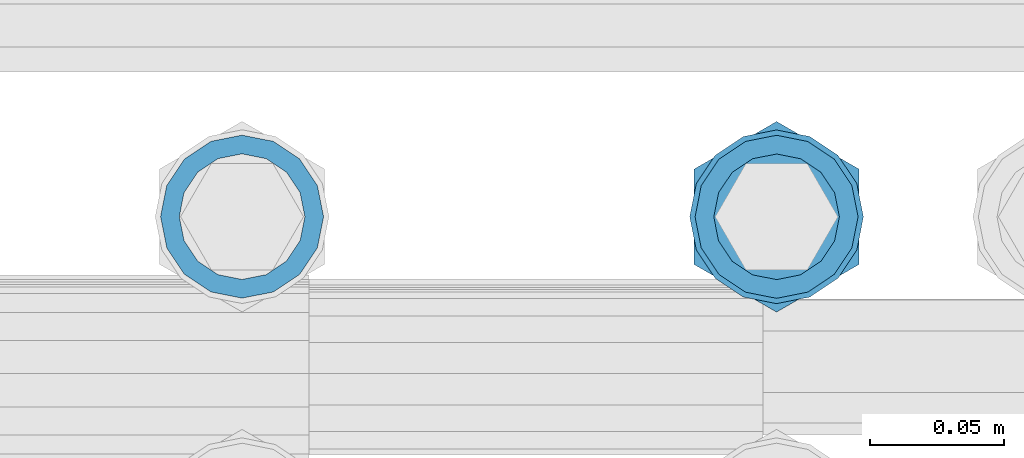
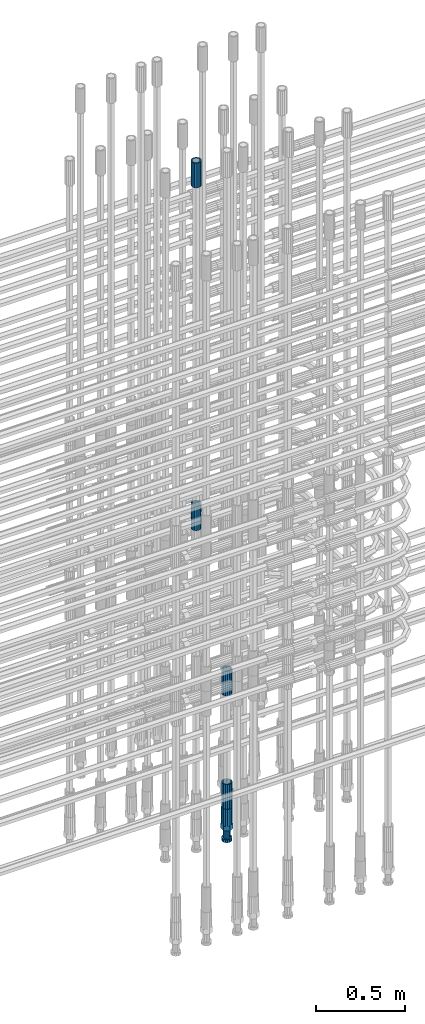
# One storey, part 18 of 119: 5 beams.
"""IFC2X3 building model written with IfcOpenShell, lengths in millimetres."""

from ifc_helpers import new_model, si_unit, frame, origin_with_axes, place, context, subcontext, project, spatial, faceted_brep, material, type_object, element, save


model = new_model("IFC2X3")

# Units and contexts
model_context = context("Model", 3, precision=1e-05, world=origin_with_axes())
body_context = subcontext(model_context, "Body", "Model", "MODEL_VIEW")
ifc_project = project(units=[si_unit("LENGTHUNIT", "METRE", prefix="MILLI"), si_unit("AREAUNIT", "SQUARE_METRE"), si_unit("VOLUMEUNIT", "CUBIC_METRE"), si_unit("MASSUNIT", "GRAM", prefix="KILO"), si_unit("TIMEUNIT", "SECOND"), si_unit("PLANEANGLEUNIT", "RADIAN"), si_unit("SOLIDANGLEUNIT", "STERADIAN"), si_unit("THERMODYNAMICTEMPERATUREUNIT", "DEGREE_CELSIUS"), si_unit("LUMINOUSINTENSITYUNIT", "LUMEN")], contexts=[model_context])

# Site, building, storey
site_placement = place(None, origin_with_axes())
site = spatial("IfcSite", under=ifc_project, at=site_placement, CompositionType="ELEMENT")
building_placement = place(site_placement, origin_with_axes())
building = spatial("IfcBuilding", under=site, at=building_placement, Name="Undefined", CompositionType="ELEMENT")
storey_placement = place(building_placement, origin_with_axes())
storey = spatial("IfcBuildingStorey", under=building, at=storey_placement, Name="Undefined", CompositionType="ELEMENT", Elevation=0.0)

# Beams
ifc_material = material(Name="STEEL/S275")
beam_type_1 = type_object("IfcBeamType", PredefinedType="NOTDEFINED")
beam_1_placement = place(storey_placement, frame((2035325.00639737, 6205269.05477611, 23229.985729163), z_axis=(1.0, 0.0, 0.0), x_axis=(0.0, 0.0, 1.0)))
element("IfcBeam", 1, at=beam_1_placement, inside=storey, type_object=beam_type_1, material=ifc_material, Name="AG40N", context=body_context, shape_type="Brep", body=[
    faceted_brep([(1.62981450557709e-09, -23.4999999990687, 0.0), (7.45058059692383e-09, -21.7111690142192, 8.99306066057534), (170.000002125278, -21.711168999318, 8.99306066022245), (170.000002127141, -23.4999999844003, -3.66071617463604e-10), (4.65661287307739e-09, -16.6170093587134, 16.6170093578889), (170.000002122484, -16.6170093440451, 16.6170093575288), (1.86264514923096e-09, -8.99306066217832, 21.7111690140277), (170.000002118759, -8.99306064750999, 21.7111690136603), (2.3283064365387e-10, 9.31322574615479e-10, 23.5), (170.000002114102, 1.28056854009628e-08, 23.4999999996485), (-6.51925802230835e-09, 8.99306065868586, 21.7111690140241), (170.00000211224, 8.99306067335419, 21.7111690136639), (-7.45058059692383e-09, 16.6170093561523, 16.6170093578853), (170.000002109446, 16.6170093708206, 16.6170093575324), (-9.31322574615479e-09, 21.711169013055, 8.99306066057534), (170.000002108514, 21.7111690277234, 8.99306066022245), (-1.16415321826935e-09, 23.5000000009313, 0.0), (170.000002108514, 23.5000000144355, -3.66071617463604e-10), (-8.38190317153931e-09, 21.7111690151505, -8.99306066059444), (170.000002110377, 21.7111690300517, -8.9930606609546), (-5.58793544769287e-09, 16.6170093598776, -16.6170093579008), (170.000002113171, 16.6170093745459, -16.6170093582609), (-9.31322574615479e-10, 8.99306066334248, -21.7111690140396), (170.000002115965, 8.99306067801081, -21.7111690143961), (2.3283064365387e-10, 9.31322574615479e-10, -23.5), (170.00000211969, 1.7927959561348e-08, -23.5000000003843), (5.58793544769287e-09, -8.99306065752171, -21.7111690140396), (170.000002123415, -8.99306064285338, -21.7111690143961), (8.38190317153931e-09, -16.6170093549881, -16.6170093579008), (170.000002125278, -16.6170093403198, -16.6170093582646), (9.31322574615479e-09, -21.7111690121237, -8.99306066059444), (170.000002127141, -21.7111689972226, -8.9930606609546), (1.11758708953857e-08, -30.4999999990687, -9.54969436861575e-12), (1.30385160446167e-08, -28.1783257392235, -11.6718446871514), (170.000002129003, -28.1783257243223, -11.6718446875116), (170.000002129935, -30.4999999841675, -3.66071617463604e-10), (1.02445483207703e-08, -21.5667568228673, -21.5667568262129), (170.000002128072, -21.566756808199, -21.5667568265694), (7.45058059692383e-09, -11.6718446831219, -28.1783257416196), (170.000002125278, -11.6718446684536, -28.1783257419834), (3.72529029846191e-09, 3.95812094211578e-09, -30.5000000000277), (170.00000211969, 1.83936208486557e-08, -30.5000000003879), (-9.31322574615479e-10, 11.6718446905725, -28.1783257416232), (170.000002115965, 11.6718447052408, -28.1783257419797), (-6.51925802230835e-09, 21.5667568286881, -21.5667568262093), (170.000002110377, 21.5667568433564, -21.5667568265694), (-9.31322574615479e-09, 28.178325742716, -11.6718446871478), (170.000002108514, 28.1783257573843, -11.6718446875079), (-1.21071934700012e-08, 30.5, -5.91171556152403e-12), (170.000002106652, 30.5000000144355, -3.62433638656512e-10), (-1.21071934700012e-08, 28.1783257401548, 11.6718446871359), (170.00000210572, 28.1783257548232, 11.6718446867794), (-1.02445483207703e-08, 21.5667568240315, 21.5667568261974), (170.000002107583, 21.566756838467, 21.5667568258409), (-7.45058059692383e-09, 11.671844684286, 28.1783257416041), (170.000002110377, 11.6718446989544, 28.178325741244), (-2.79396772384644e-09, -2.56113708019257e-09, 30.5000000000159), (170.000002114102, 1.18743628263474e-08, 30.4999999996558), (1.86264514923096e-09, -11.6718446896411, 28.1783257416114), (170.000002118759, -11.67184467474, 28.178325741244), (7.45058059692383e-09, -21.5667568275239, 21.5667568261974), (170.000002123415, -21.5667568126228, 21.5667568258373), (1.02445483207703e-08, -28.1783257415518, 11.6718446871359), (170.000002127141, -28.1783257271163, 11.6718446867794)], [[[0, 1, 2, 3]], [[1, 4, 5, 2]], [[4, 6, 7, 5]], [[6, 8, 9, 7]], [[8, 10, 11, 9]], [[10, 12, 13, 11]], [[12, 14, 15, 13]], [[14, 16, 17, 15]], [[16, 18, 19, 17]], [[18, 20, 21, 19]], [[20, 22, 23, 21]], [[22, 24, 25, 23]], [[24, 26, 27, 25]], [[26, 28, 29, 27]], [[28, 30, 31, 29]], [[30, 0, 3, 31]], [[32, 33, 34, 35]], [[33, 36, 37, 34]], [[36, 38, 39, 37]], [[38, 40, 41, 39]], [[40, 42, 43, 41]], [[42, 44, 45, 43]], [[44, 46, 47, 45]], [[46, 48, 49, 47]], [[48, 50, 51, 49]], [[50, 52, 53, 51]], [[52, 54, 55, 53]], [[54, 56, 57, 55]], [[56, 58, 59, 57]], [[58, 60, 61, 59]], [[60, 62, 63, 61]], [[62, 32, 35, 63]], [[37, 39, 41, 43, 45, 47, 49, 51, 53, 55, 57, 59, 61, 63, 35, 34], [5, 7, 9, 11, 13, 15, 17, 19, 21, 23, 25, 27, 29, 31, 3, 2]], [[62, 60, 58, 56, 54, 52, 50, 48, 46, 44, 42, 40, 38, 36, 33, 32], [30, 28, 26, 24, 22, 20, 18, 16, 14, 12, 10, 8, 6, 4, 1, 0]]]),
])
beam_2_placement = place(storey_placement, frame((2035325.00639737, 6205269.05477611, 21044.6068583132), z_axis=(-0.99999999999998, 1.98000110685822e-07, 0.0), x_axis=(0.0, 0.0, -1.0)))
element("IfcBeam", 2, at=beam_2_placement, inside=storey, type_object=beam_type_1, material=ifc_material, Name="AG40N", context=body_context, shape_type="Brep", body=[
    faceted_brep([(1.62981450557709e-09, -23.4999999990687, 0.0), (7.45058059692383e-09, -21.7111690142192, 8.99306066057534), (170.000002125278, -21.711168999318, 8.99306066022245), (170.000002127141, -23.4999999844003, -3.66071617463604e-10), (4.65661287307739e-09, -16.6170093587134, 16.6170093578889), (170.000002122484, -16.6170093440451, 16.6170093575288), (1.86264514923096e-09, -8.99306066217832, 21.7111690140277), (170.000002118759, -8.99306064750999, 21.7111690136603), (2.3283064365387e-10, 9.31322574615479e-10, 23.5), (170.000002114102, 1.28056854009628e-08, 23.4999999996485), (-6.51925802230835e-09, 8.99306065868586, 21.7111690140241), (170.00000211224, 8.99306067335419, 21.7111690136639), (-7.45058059692383e-09, 16.6170093561523, 16.6170093578853), (170.000002109446, 16.6170093708206, 16.6170093575324), (-9.31322574615479e-09, 21.711169013055, 8.99306066057534), (170.000002108514, 21.7111690277234, 8.99306066022245), (-1.16415321826935e-09, 23.5000000009313, 0.0), (170.000002108514, 23.5000000144355, -3.66071617463604e-10), (-8.38190317153931e-09, 21.7111690151505, -8.99306066059444), (170.000002110377, 21.7111690300517, -8.9930606609546), (-5.58793544769287e-09, 16.6170093598776, -16.6170093579008), (170.000002113171, 16.6170093745459, -16.6170093582609), (-9.31322574615479e-10, 8.99306066334248, -21.7111690140396), (170.000002115965, 8.99306067801081, -21.7111690143961), (2.3283064365387e-10, 9.31322574615479e-10, -23.5), (170.00000211969, 1.7927959561348e-08, -23.5000000003843), (5.58793544769287e-09, -8.99306065752171, -21.7111690140396), (170.000002123415, -8.99306064285338, -21.7111690143961), (8.38190317153931e-09, -16.6170093549881, -16.6170093579008), (170.000002125278, -16.6170093403198, -16.6170093582646), (9.31322574615479e-09, -21.7111690121237, -8.99306066059444), (170.000002127141, -21.7111689972226, -8.9930606609546), (1.11758708953857e-08, -30.4999999990687, -9.54969436861575e-12), (1.30385160446167e-08, -28.1783257392235, -11.6718446871514), (170.000002129003, -28.1783257243223, -11.6718446875116), (170.000002129935, -30.4999999841675, -3.66071617463604e-10), (1.02445483207703e-08, -21.5667568228673, -21.5667568262129), (170.000002128072, -21.566756808199, -21.5667568265694), (7.45058059692383e-09, -11.6718446831219, -28.1783257416196), (170.000002125278, -11.6718446684536, -28.1783257419834), (3.72529029846191e-09, 3.95812094211578e-09, -30.5000000000277), (170.00000211969, 1.83936208486557e-08, -30.5000000003879), (-9.31322574615479e-10, 11.6718446905725, -28.1783257416232), (170.000002115965, 11.6718447052408, -28.1783257419797), (-6.51925802230835e-09, 21.5667568286881, -21.5667568262093), (170.000002110377, 21.5667568433564, -21.5667568265694), (-9.31322574615479e-09, 28.178325742716, -11.6718446871478), (170.000002108514, 28.1783257573843, -11.6718446875079), (-1.21071934700012e-08, 30.5, -5.91171556152403e-12), (170.000002106652, 30.5000000144355, -3.62433638656512e-10), (-1.21071934700012e-08, 28.1783257401548, 11.6718446871359), (170.00000210572, 28.1783257548232, 11.6718446867794), (-1.02445483207703e-08, 21.5667568240315, 21.5667568261974), (170.000002107583, 21.566756838467, 21.5667568258409), (-7.45058059692383e-09, 11.671844684286, 28.1783257416041), (170.000002110377, 11.6718446989544, 28.178325741244), (-2.79396772384644e-09, -2.56113708019257e-09, 30.5000000000159), (170.000002114102, 1.18743628263474e-08, 30.4999999996558), (1.86264514923096e-09, -11.6718446896411, 28.1783257416114), (170.000002118759, -11.67184467474, 28.178325741244), (7.45058059692383e-09, -21.5667568275239, 21.5667568261974), (170.000002123415, -21.5667568126228, 21.5667568258373), (1.02445483207703e-08, -28.1783257415518, 11.6718446871359), (170.000002127141, -28.1783257271163, 11.6718446867794)], [[[0, 1, 2, 3]], [[1, 4, 5, 2]], [[4, 6, 7, 5]], [[6, 8, 9, 7]], [[8, 10, 11, 9]], [[10, 12, 13, 11]], [[12, 14, 15, 13]], [[14, 16, 17, 15]], [[16, 18, 19, 17]], [[18, 20, 21, 19]], [[20, 22, 23, 21]], [[22, 24, 25, 23]], [[24, 26, 27, 25]], [[26, 28, 29, 27]], [[28, 30, 31, 29]], [[30, 0, 3, 31]], [[32, 33, 34, 35]], [[33, 36, 37, 34]], [[36, 38, 39, 37]], [[38, 40, 41, 39]], [[40, 42, 43, 41]], [[42, 44, 45, 43]], [[44, 46, 47, 45]], [[46, 48, 49, 47]], [[48, 50, 51, 49]], [[50, 52, 53, 51]], [[52, 54, 55, 53]], [[54, 56, 57, 55]], [[56, 58, 59, 57]], [[58, 60, 61, 59]], [[60, 62, 63, 61]], [[62, 32, 35, 63]], [[37, 39, 41, 43, 45, 47, 49, 51, 53, 55, 57, 59, 61, 63, 35, 34], [5, 7, 9, 11, 13, 15, 17, 19, 21, 23, 25, 27, 29, 31, 3, 2]], [[62, 60, 58, 56, 54, 52, 50, 48, 46, 44, 42, 40, 38, 36, 33, 32], [30, 28, 26, 24, 22, 20, 18, 16, 14, 12, 10, 8, 6, 4, 1, 0]]]),
])
beam_3_placement = place(storey_placement, frame((2035525.00620663, 6205269.00125114, 19667.715729163), z_axis=(1.0, 0.0, 0.0), x_axis=(0.0, 0.0, 1.0)))
element("IfcBeam", 3, at=beam_3_placement, inside=storey, type_object=beam_type_1, material=ifc_material, Name="AG40N", context=body_context, shape_type="Brep", body=[
    faceted_brep([(1.62981450557709e-09, -23.4999999990687, 0.0), (7.45058059692383e-09, -21.7111690142192, 8.99306066057534), (170.000002125278, -21.711168999318, 8.99306066022245), (170.000002127141, -23.4999999844003, -3.66071617463604e-10), (4.65661287307739e-09, -16.6170093587134, 16.6170093578889), (170.000002122484, -16.6170093440451, 16.6170093575288), (1.86264514923096e-09, -8.99306066217832, 21.7111690140277), (170.000002118759, -8.99306064750999, 21.7111690136603), (2.3283064365387e-10, 9.31322574615479e-10, 23.5), (170.000002114102, 1.28056854009628e-08, 23.4999999996485), (-6.51925802230835e-09, 8.99306065868586, 21.7111690140241), (170.00000211224, 8.99306067335419, 21.7111690136639), (-7.45058059692383e-09, 16.6170093561523, 16.6170093578853), (170.000002109446, 16.6170093708206, 16.6170093575324), (-9.31322574615479e-09, 21.711169013055, 8.99306066057534), (170.000002108514, 21.7111690277234, 8.99306066022245), (-1.16415321826935e-09, 23.5000000009313, 0.0), (170.000002108514, 23.5000000144355, -3.66071617463604e-10), (-8.38190317153931e-09, 21.7111690151505, -8.99306066059444), (170.000002110377, 21.7111690300517, -8.9930606609546), (-5.58793544769287e-09, 16.6170093598776, -16.6170093579008), (170.000002113171, 16.6170093745459, -16.6170093582609), (-9.31322574615479e-10, 8.99306066334248, -21.7111690140396), (170.000002115965, 8.99306067801081, -21.7111690143961), (2.3283064365387e-10, 9.31322574615479e-10, -23.5), (170.00000211969, 1.7927959561348e-08, -23.5000000003843), (5.58793544769287e-09, -8.99306065752171, -21.7111690140396), (170.000002123415, -8.99306064285338, -21.7111690143961), (8.38190317153931e-09, -16.6170093549881, -16.6170093579008), (170.000002125278, -16.6170093403198, -16.6170093582646), (9.31322574615479e-09, -21.7111690121237, -8.99306066059444), (170.000002127141, -21.7111689972226, -8.9930606609546), (1.11758708953857e-08, -30.4999999990687, -9.54969436861575e-12), (1.30385160446167e-08, -28.1783257392235, -11.6718446871514), (170.000002129003, -28.1783257243223, -11.6718446875116), (170.000002129935, -30.4999999841675, -3.66071617463604e-10), (1.02445483207703e-08, -21.5667568228673, -21.5667568262129), (170.000002128072, -21.566756808199, -21.5667568265694), (7.45058059692383e-09, -11.6718446831219, -28.1783257416196), (170.000002125278, -11.6718446684536, -28.1783257419834), (3.72529029846191e-09, 3.95812094211578e-09, -30.5000000000277), (170.00000211969, 1.83936208486557e-08, -30.5000000003879), (-9.31322574615479e-10, 11.6718446905725, -28.1783257416232), (170.000002115965, 11.6718447052408, -28.1783257419797), (-6.51925802230835e-09, 21.5667568286881, -21.5667568262093), (170.000002110377, 21.5667568433564, -21.5667568265694), (-9.31322574615479e-09, 28.178325742716, -11.6718446871478), (170.000002108514, 28.1783257573843, -11.6718446875079), (-1.21071934700012e-08, 30.5, -5.91171556152403e-12), (170.000002106652, 30.5000000144355, -3.62433638656512e-10), (-1.21071934700012e-08, 28.1783257401548, 11.6718446871359), (170.00000210572, 28.1783257548232, 11.6718446867794), (-1.02445483207703e-08, 21.5667568240315, 21.5667568261974), (170.000002107583, 21.566756838467, 21.5667568258409), (-7.45058059692383e-09, 11.671844684286, 28.1783257416041), (170.000002110377, 11.6718446989544, 28.178325741244), (-2.79396772384644e-09, -2.56113708019257e-09, 30.5000000000159), (170.000002114102, 1.18743628263474e-08, 30.4999999996558), (1.86264514923096e-09, -11.6718446896411, 28.1783257416114), (170.000002118759, -11.67184467474, 28.178325741244), (7.45058059692383e-09, -21.5667568275239, 21.5667568261974), (170.000002123415, -21.5667568126228, 21.5667568258373), (1.02445483207703e-08, -28.1783257415518, 11.6718446871359), (170.000002127141, -28.1783257271163, 11.6718446867794)], [[[0, 1, 2, 3]], [[1, 4, 5, 2]], [[4, 6, 7, 5]], [[6, 8, 9, 7]], [[8, 10, 11, 9]], [[10, 12, 13, 11]], [[12, 14, 15, 13]], [[14, 16, 17, 15]], [[16, 18, 19, 17]], [[18, 20, 21, 19]], [[20, 22, 23, 21]], [[22, 24, 25, 23]], [[24, 26, 27, 25]], [[26, 28, 29, 27]], [[28, 30, 31, 29]], [[30, 0, 3, 31]], [[32, 33, 34, 35]], [[33, 36, 37, 34]], [[36, 38, 39, 37]], [[38, 40, 41, 39]], [[40, 42, 43, 41]], [[42, 44, 45, 43]], [[44, 46, 47, 45]], [[46, 48, 49, 47]], [[48, 50, 51, 49]], [[50, 52, 53, 51]], [[52, 54, 55, 53]], [[54, 56, 57, 55]], [[56, 58, 59, 57]], [[58, 60, 61, 59]], [[60, 62, 63, 61]], [[62, 32, 35, 63]], [[37, 39, 41, 43, 45, 47, 49, 51, 53, 55, 57, 59, 61, 63, 35, 34], [5, 7, 9, 11, 13, 15, 17, 19, 21, 23, 25, 27, 29, 31, 3, 2]], [[62, 60, 58, 56, 54, 52, 50, 48, 46, 44, 42, 40, 38, 36, 33, 32], [30, 28, 26, 24, 22, 20, 18, 16, 14, 12, 10, 8, 6, 4, 1, 0]]]),
])
beam_4_placement = place(storey_placement, frame((2035525.00620663, 6205269.00125114, 19060.9568583139), z_axis=(-0.99999999999998, 1.98000110685822e-07, 0.0), x_axis=(0.0, 0.0, -1.0)))
element("IfcBeam", 4, at=beam_4_placement, inside=storey, type_object=beam_type_1, material=ifc_material, Name="AG40N", context=body_context, shape_type="Brep", body=[
    faceted_brep([(1.62981450557709e-09, -23.4999999990687, 0.0), (7.45058059692383e-09, -21.7111690142192, 8.99306066057534), (170.000002125278, -21.711168999318, 8.99306066022245), (170.000002127141, -23.4999999844003, -3.66071617463604e-10), (4.65661287307739e-09, -16.6170093587134, 16.6170093578889), (170.000002122484, -16.6170093440451, 16.6170093575288), (1.86264514923096e-09, -8.99306066217832, 21.7111690140277), (170.000002118759, -8.99306064750999, 21.7111690136603), (2.3283064365387e-10, 9.31322574615479e-10, 23.5), (170.000002114102, 1.28056854009628e-08, 23.4999999996485), (-6.51925802230835e-09, 8.99306065868586, 21.7111690140241), (170.00000211224, 8.99306067335419, 21.7111690136639), (-7.45058059692383e-09, 16.6170093561523, 16.6170093578853), (170.000002109446, 16.6170093708206, 16.6170093575324), (-9.31322574615479e-09, 21.711169013055, 8.99306066057534), (170.000002108514, 21.7111690277234, 8.99306066022245), (-1.16415321826935e-09, 23.5000000009313, 0.0), (170.000002108514, 23.5000000144355, -3.66071617463604e-10), (-8.38190317153931e-09, 21.7111690151505, -8.99306066059444), (170.000002110377, 21.7111690300517, -8.9930606609546), (-5.58793544769287e-09, 16.6170093598776, -16.6170093579008), (170.000002113171, 16.6170093745459, -16.6170093582609), (-9.31322574615479e-10, 8.99306066334248, -21.7111690140396), (170.000002115965, 8.99306067801081, -21.7111690143961), (2.3283064365387e-10, 9.31322574615479e-10, -23.5), (170.00000211969, 1.7927959561348e-08, -23.5000000003843), (5.58793544769287e-09, -8.99306065752171, -21.7111690140396), (170.000002123415, -8.99306064285338, -21.7111690143961), (8.38190317153931e-09, -16.6170093549881, -16.6170093579008), (170.000002125278, -16.6170093403198, -16.6170093582646), (9.31322574615479e-09, -21.7111690121237, -8.99306066059444), (170.000002127141, -21.7111689972226, -8.9930606609546), (1.11758708953857e-08, -30.4999999990687, -9.54969436861575e-12), (1.30385160446167e-08, -28.1783257392235, -11.6718446871514), (170.000002129003, -28.1783257243223, -11.6718446875116), (170.000002129935, -30.4999999841675, -3.66071617463604e-10), (1.02445483207703e-08, -21.5667568228673, -21.5667568262129), (170.000002128072, -21.566756808199, -21.5667568265694), (7.45058059692383e-09, -11.6718446831219, -28.1783257416196), (170.000002125278, -11.6718446684536, -28.1783257419834), (3.72529029846191e-09, 3.95812094211578e-09, -30.5000000000277), (170.00000211969, 1.83936208486557e-08, -30.5000000003879), (-9.31322574615479e-10, 11.6718446905725, -28.1783257416232), (170.000002115965, 11.6718447052408, -28.1783257419797), (-6.51925802230835e-09, 21.5667568286881, -21.5667568262093), (170.000002110377, 21.5667568433564, -21.5667568265694), (-9.31322574615479e-09, 28.178325742716, -11.6718446871478), (170.000002108514, 28.1783257573843, -11.6718446875079), (-1.21071934700012e-08, 30.5, -5.91171556152403e-12), (170.000002106652, 30.5000000144355, -3.62433638656512e-10), (-1.21071934700012e-08, 28.1783257401548, 11.6718446871359), (170.00000210572, 28.1783257548232, 11.6718446867794), (-1.02445483207703e-08, 21.5667568240315, 21.5667568261974), (170.000002107583, 21.566756838467, 21.5667568258409), (-7.45058059692383e-09, 11.671844684286, 28.1783257416041), (170.000002110377, 11.6718446989544, 28.178325741244), (-2.79396772384644e-09, -2.56113708019257e-09, 30.5000000000159), (170.000002114102, 1.18743628263474e-08, 30.4999999996558), (1.86264514923096e-09, -11.6718446896411, 28.1783257416114), (170.000002118759, -11.67184467474, 28.178325741244), (7.45058059692383e-09, -21.5667568275239, 21.5667568261974), (170.000002123415, -21.5667568126228, 21.5667568258373), (1.02445483207703e-08, -28.1783257415518, 11.6718446871359), (170.000002127141, -28.1783257271163, 11.6718446867794)], [[[0, 1, 2, 3]], [[1, 4, 5, 2]], [[4, 6, 7, 5]], [[6, 8, 9, 7]], [[8, 10, 11, 9]], [[10, 12, 13, 11]], [[12, 14, 15, 13]], [[14, 16, 17, 15]], [[16, 18, 19, 17]], [[18, 20, 21, 19]], [[20, 22, 23, 21]], [[22, 24, 25, 23]], [[24, 26, 27, 25]], [[26, 28, 29, 27]], [[28, 30, 31, 29]], [[30, 0, 3, 31]], [[32, 33, 34, 35]], [[33, 36, 37, 34]], [[36, 38, 39, 37]], [[38, 40, 41, 39]], [[40, 42, 43, 41]], [[42, 44, 45, 43]], [[44, 46, 47, 45]], [[46, 48, 49, 47]], [[48, 50, 51, 49]], [[50, 52, 53, 51]], [[52, 54, 55, 53]], [[54, 56, 57, 55]], [[56, 58, 59, 57]], [[58, 60, 61, 59]], [[60, 62, 63, 61]], [[62, 32, 35, 63]], [[37, 39, 41, 43, 45, 47, 49, 51, 53, 55, 57, 59, 61, 63, 35, 34], [5, 7, 9, 11, 13, 15, 17, 19, 21, 23, 25, 27, 29, 31, 3, 2]], [[62, 60, 58, 56, 54, 52, 50, 48, 46, 44, 42, 40, 38, 36, 33, 32], [30, 28, 26, 24, 22, 20, 18, 16, 14, 12, 10, 8, 6, 4, 1, 0]]]),
])
beam_type_2 = type_object("IfcBeamType", Name="ROD65", PredefinedType="NOTDEFINED")
beam_5_placement = place(storey_placement, frame((2035525.00620663, 6205269.00125114, 18890.9568583139), z_axis=(-0.99999999999998, 1.98000110685822e-07, 0.0), x_axis=(0.0, 0.0, -1.0)))
element("IfcBeam", 5, at=beam_5_placement, inside=storey, type_object=beam_type_2, material=ifc_material, Name="AGB40", ObjectType="ROD65", context=body_context, shape_type="Brep", body=[
    faceted_brep([(116.999999999069, 17.8249999252148, 30.8738056446964), (116.999999998137, 22.0056957420893, 23.632628078838), (116.999999999069, 12.4372115600854, 30.0260848066173), (116.999999999069, 8.17543111252598, 30.8738056446964), (117.000000000931, -17.8250000746921, 30.8738056446964), (150.200000001118, -17.8250000723638, 30.8738056446964), (150.199999999255, 17.8249999275431, 30.8738056446964), (117.000000000931, -8.17543109622784, 30.8738056446964), (117.000000001863, -22.0056959956419, 23.6326278985034), (117.000000000931, -12.4372115437873, 30.0260848066173), (117.000000001863, -35.6500000746455, -2.18278728425503e-10), (150.200000002049, -35.6500000723172, -2.18278728425503e-10), (117.000000001863, -30.8443149488885, 8.32369080289209), (117.000000001863, -30.8443149488885, -8.32369080355784), (117.000000002794, -32.4999999918509, 0.0), (117.000000000931, -17.8250000746921, -30.873805645133), (150.200000001118, -17.8250000723638, -30.873805645133), (117.000000001863, -22.0056959961075, -23.6326278982269), (117.000000000931, -8.17543109389953, -30.873805645133), (117.000000000931, -12.4372115437873, -30.0260848066173), (116.999999999069, 17.8249999252148, -30.873805645133), (150.199999999255, 17.8249999275431, -30.873805645133), (116.999999999069, 8.17543111019768, -30.873805645133), (116.999999999069, 12.4372115600854, -30.0260848066173), (116.999999998137, 22.005695742555, -23.6326280785652), (116.999999998137, 35.6499999251682, -2.18278728425503e-10), (150.199999998324, 35.6499999277294, -2.18278728425503e-10), (116.999999998137, 30.8443150522653, -8.32369036550881), (116.999999997206, 32.5000000081491, 0.0), (116.999999998137, 30.8443150522653, 8.32369036483942), (1.86264514923096e-09, -22.9809703885112, 22.9809703885621), (1.86264514923096e-09, -30.0260848065373, 12.4372115518672), (117.000000001863, -30.0260847983882, 12.4372115518672), (117.000000001863, -22.9809703803621, 22.9809703885621), (-1.86264514923096e-09, 22.9809703885112, -22.9809703885621), (-1.86264514923096e-09, 30.0260848065373, -12.4372115518672), (116.999999998137, 30.0260848146863, -12.4372115518672), (116.999999998137, 22.9809703966603, -22.9809703885621), (1.86264514923096e-09, -30.0260848065373, -12.4372115518672), (1.86264514923096e-09, -22.9809703885112, -22.9809703885621), (117.000000001863, -22.9809703803621, -22.9809703885621), (117.000000001863, -30.0260847983882, -12.4372115518672), (9.31322574615479e-10, -12.4372115519363, 30.0260848066173), (0.0, 0.0, 32.5), (-9.31322574615479e-10, 12.4372115519363, 30.0260848066173), (-1.86264514923096e-09, 22.9809703885112, 22.9809703885621), (-1.86264514923096e-09, 30.0260848065373, 12.4372115518672), (-2.79396772384644e-09, 32.5, 0.0), (-9.31322574615479e-10, 12.4372115519363, -30.0260848066173), (0.0, 0.0, -32.5), (9.31322574615479e-10, -12.4372115519363, -30.0260848066173), (2.79396772384644e-09, -32.5, 0.0), (116.999999998137, 22.9809703966603, 22.9809703885621), (116.999999998137, 30.0260848146863, 12.4372115518672), (117.0, 8.14907252788544e-09, -32.5), (117.0, 8.14907252788544e-09, 32.5), (150.200000000186, -10.5000000959262, 18.1865334791873), (150.199999999255, -9.59262251853943e-08, 20.9999999997126), (150.199999998324, 10.4999999040738, 18.1865334791873), (150.199999997392, 18.1865333835594, 10.4999999997126), (150.199999997392, 20.9999999040738, -2.87400325760245e-10), (150.199999997392, 18.1865333835594, -10.5000000002874), (150.199999998324, 10.4999999040738, -18.1865334797621), (150.199999999255, -9.59262251853943e-08, -21.0000000002874), (150.200000000186, -10.5000000959262, -18.1865334797621), (150.200000000186, -18.1865335754119, -10.5000000002874), (150.200000001118, -21.0000000959262, -2.87400325760245e-10), (150.200000000186, -18.1865335754119, 10.4999999997126), (210.979999999516, 10.4999999082647, 18.1865334791873), (210.979999999516, -9.17352735996246e-08, 20.9999999997126), (210.979999997653, 18.1865333877504, 10.4999999997126), (210.979999997653, 20.9999999082647, -2.87400325760245e-10), (210.979999997653, 18.1865333877504, -10.5000000002874), (210.979999999516, 10.4999999082647, -18.1865334797621), (210.979999999516, -9.17352735996246e-08, -21.0000000002874), (210.979999999516, -10.5000000917353, -18.1865334797621), (210.980000000447, -18.1865335712209, -10.5000000002874), (210.980000001378, -21.0000000917353, -2.87400325760245e-10), (210.980000000447, -18.1865335712209, 10.4999999997126), (210.979999999516, -10.5000000917353, 18.1865334791873), (211.001368402503, -27.7269939335529, -11.4911163272045), (211.003082515672, -21.2238095656503, -21.2238154190527), (231.002518340945, -21.2131946226582, -21.2132004554769), (231.000804228708, -27.7163789905608, -11.4805013636287), (211.001368415542, -11.4911086384673, -27.7269970399575), (231.000804241747, -11.4804936954752, -27.7163820763781), (210.996487061493, -0.0106066407170147, -30.0106107396168), (230.995922887698, 8.30227509140968e-06, -29.999995776041), (210.98918159306, 11.4698940692469, -27.7269970332745), (230.988617419265, 11.4805090120062, -27.7163820696951), (210.980564201251, 21.2025913291145, -21.2238154067054), (230.980000027455, 21.2132062721066, -21.2132004431296), (210.971946807578, 27.7057702087332, -11.4911163110701), (230.971382633783, 27.7163851517253, -11.4805013474943), (210.964641331695, 29.9893806746695, -0.0106149565435771), (230.9640771579, 29.9999956176616, 7.03221303410828e-09), (210.959759964608, 27.7057637346443, 11.4698863966551), (230.959195790812, 27.7163786776364, 11.4805013602345), (210.958045851439, 21.2025793667417, 21.2025854885032), (230.957481677644, 21.2131943097338, 21.2132004520827), (210.959759951569, 11.4698784395587, 27.705767109408), (230.959195776843, 11.4804933823179, 27.7163820729838), (210.964641305618, -0.0106235581915826, 29.9893808090674), (230.964077131823, -8.61519947648048e-06, 29.9999957726432), (210.971946774051, -11.4911242681555, 27.7057671027251), (230.971382599324, -11.4805093251634, 27.7163820663009), (210.98056416586, -21.2238215280231, 21.2025854761559), (230.979999991134, -21.2132065852638, 21.2132004397354), (210.989181559533, -27.7270004076418, 11.4698863805206), (230.988617384806, -27.7163854646496, 11.4805013441), (210.996487035416, -30.0106108735781, -0.0106149740058754), (230.995922861621, -29.999995930586, -1.04300852399319e-08)], [[[0, 1, 2, 3]], [[4, 5, 6, 0, 3, 7]], [[8, 4, 7, 9]], [[10, 11, 5, 4, 8, 12]], [[13, 10, 12, 14]], [[15, 16, 11, 10, 13, 17]], [[18, 15, 17, 19]], [[20, 21, 16, 15, 18, 22]], [[20, 22, 23, 24]], [[25, 26, 21, 20, 24, 27]], [[25, 27, 28, 29]], [[30, 31, 32, 33]], [[34, 35, 36, 37]], [[38, 39, 40, 41]], [[31, 30, 42, 43, 44, 45, 46, 47, 35, 34, 48, 49, 50, 39, 38, 51]], [[46, 45, 52, 53]], [[28, 47, 46, 53, 29]], [[27, 36, 35, 47, 28]], [[24, 37, 36, 27]], [[23, 48, 34, 37, 24]], [[22, 54, 49, 48, 23]], [[18, 54, 22]], [[19, 50, 49, 54, 18]], [[17, 40, 39, 50, 19]], [[13, 41, 40, 17]], [[14, 51, 38, 41, 13]], [[12, 32, 31, 51, 14]], [[8, 33, 32, 12]], [[9, 42, 30, 33, 8]], [[7, 55, 43, 42, 9]], [[3, 55, 7]], [[2, 44, 43, 55, 3]], [[1, 52, 45, 44, 2]], [[29, 53, 52, 1]], [[0, 6, 26, 25, 29, 1]], [[5, 11, 16, 21, 26, 6], [56, 57, 58, 59, 60, 61, 62, 63, 64, 65, 66, 67]], [[68, 58, 57, 69]], [[70, 59, 58, 68]], [[71, 60, 59, 70]], [[72, 61, 60, 71]], [[73, 62, 61, 72]], [[74, 63, 62, 73]], [[75, 64, 63, 74]], [[76, 65, 64, 75]], [[77, 66, 65, 76]], [[78, 67, 66, 77]], [[79, 56, 67, 78]], [[69, 57, 56, 79]], [[80, 81, 82, 83]], [[81, 84, 85, 82]], [[84, 86, 87, 85]], [[86, 88, 89, 87]], [[88, 90, 91, 89]], [[90, 92, 93, 91]], [[92, 94, 95, 93]], [[94, 96, 97, 95]], [[96, 98, 99, 97]], [[98, 100, 101, 99]], [[100, 102, 103, 101]], [[102, 104, 105, 103]], [[104, 106, 107, 105]], [[106, 108, 109, 107]], [[108, 110, 111, 109]], [[82, 85, 87, 89, 91, 93, 95, 97, 99, 101, 103, 105, 107, 109, 111, 83]], [[110, 80, 83, 111]], [[108, 106, 104, 102, 100, 98, 96, 94, 92, 90, 88, 86, 84, 81, 80, 110], [78, 77, 76, 75, 74, 73, 72, 71, 70, 68, 69, 79]]]),
])

save(model, "model.ifc")
